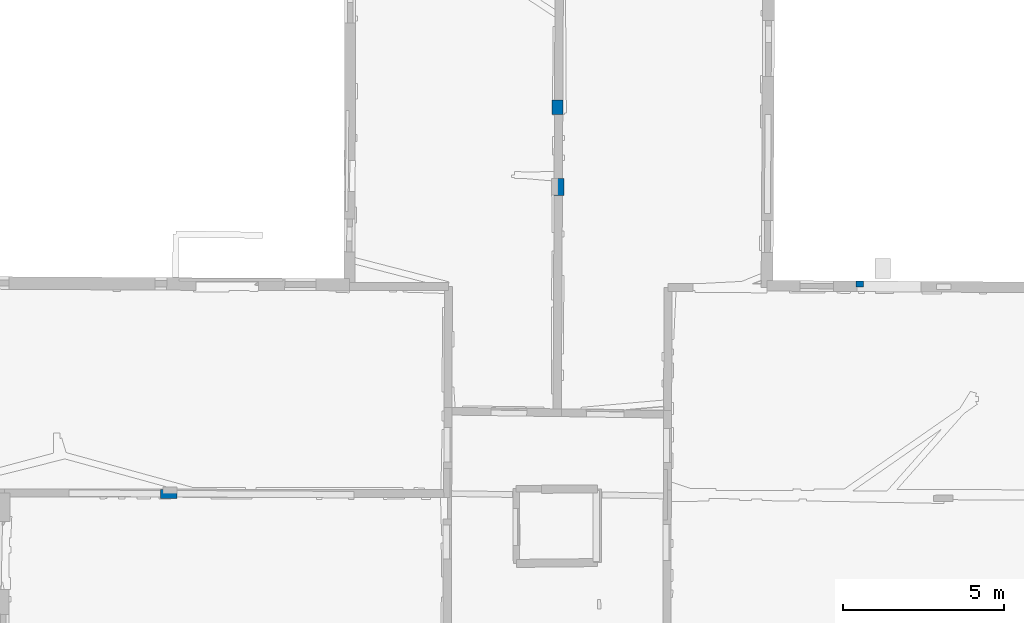
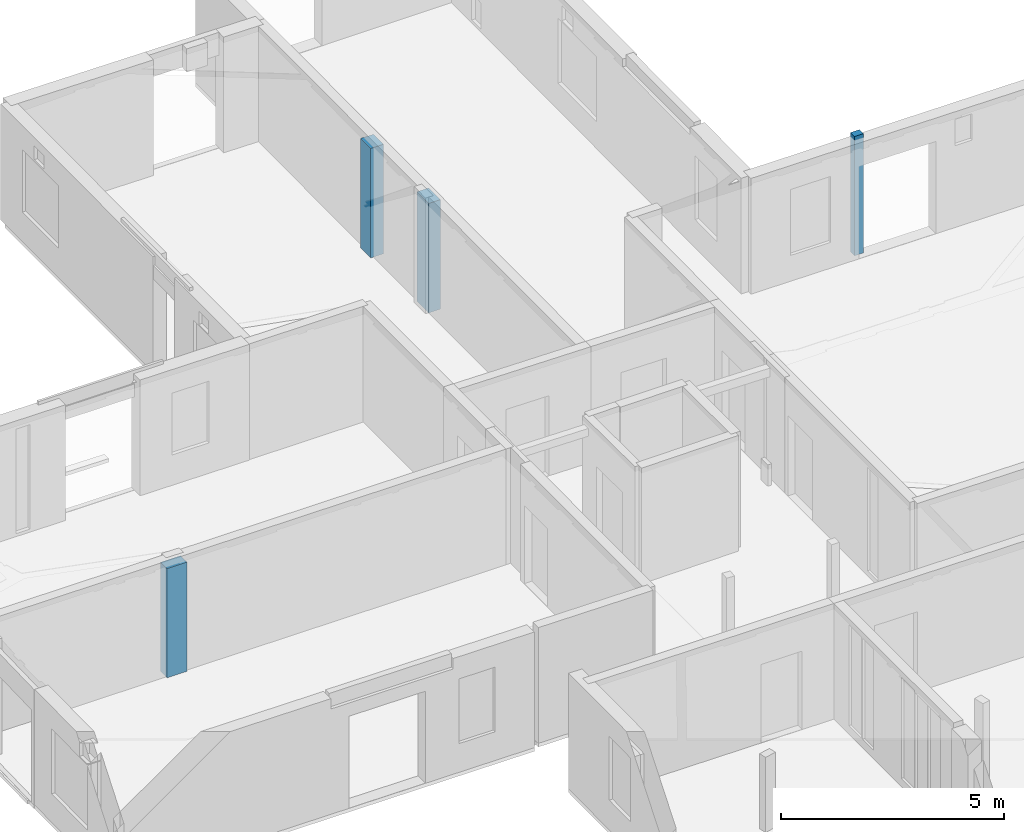
# One storey, part 2 of 17: 4 columns.
"""IFC2X3 building model written with IfcOpenShell, lengths in metres."""

import ifcopenshell
import ifcopenshell.guid

model = None  # the IFC model being written
_history = None  # IfcOwnerHistory: only IFC2X3 demands one
_inside = {}  # id of a spatial element -> (the spatial element, [elements in it])
_under = {}  # id of a project, library or spatial element -> (it, [spatial elements below it])
_declared = {}  # id of a project -> (the project, [libraries it declares])
_typed = {}  # id of a type object -> (the type object, [elements of that type])
_made_of = {}  # id of a material, layer set ... -> (it, [elements and type objects made of it])


def new_model(schema):
    """Start an empty IFC model of exactly this schema.

    Asked for "IFC4X3", IfcOpenShell would pick the latest addendum, in which some entities
    have other attributes; the version numbers below select the first issue.
    IFC2X3 requires an IfcOwnerHistory on every rooted entity: one is made here for all.
    """
    global model, _history
    if schema == "IFC4X3":
        model = ifcopenshell.file(schema_version=(4, 3, 0, 0))
    else:
        model = ifcopenshell.file(schema=schema)
    _inside.clear()
    _under.clear()
    _declared.clear()
    _typed.clear()
    _made_of.clear()
    _history = None
    if model.schema == "IFC2X3":
        org = make("IfcOrganization", Name="unknown")
        user = make(
            "IfcPersonAndOrganization",
            ThePerson=make("IfcPerson", FamilyName="unknown"),
            TheOrganization=org,
        )
        app = make(
            "IfcApplication",
            ApplicationDeveloper=org,
            Version="unknown",
            ApplicationFullName="unknown",
            ApplicationIdentifier="unknown",
        )
        _history = make(
            "IfcOwnerHistory",
            OwningUser=user,
            OwningApplication=app,
            ChangeAction="ADDED",
            CreationDate=0,
        )
    return model


def make(cls, **values):
    """One entity of the class cls with the attributes given. An attribute that is None is left unset."""
    return model.create_entity(
        cls, **{name: value for name, value in values.items() if value is not None}
    )


def entity(cls, *values):
    """Any entity or typed value of the class cls, its attributes in the order of the schema. None: left unset."""
    e = model.create_entity(cls)
    for i, value in enumerate(values):
        if value is not None:
            e[i] = value
    return e


def rooted(cls, **values):
    """An entity with a GlobalId (a new one), such as an element, a storey or a relation."""
    return make(cls, GlobalId=ifcopenshell.guid.new(), OwnerHistory=_history, **values)


def si_unit(unit_type, name, prefix=None):
    """IfcSIUnit, for example si_unit("LENGTHUNIT", "METRE", prefix="MILLI")."""
    return make("IfcSIUnit", UnitType=unit_type, Prefix=prefix, Name=name)


def converted_unit(unit_type, name, factor, base, dimensions=None, offset=None):
    """IfcConversionBasedUnit, such as the inch: factor (a typed value) times the base unit."""
    return make(
        "IfcConversionBasedUnit"
        if offset is None
        else "IfcConversionBasedUnitWithOffset",
        ConversionOffset=offset,
        Dimensions=None
        if dimensions is None
        else entity("IfcDimensionalExponents", *dimensions),
        UnitType=unit_type,
        Name=name,
        ConversionFactor=make(
            "IfcMeasureWithUnit", ValueComponent=factor, UnitComponent=base
        ),
    )


def derived_unit(unit_type, elements):
    """IfcDerivedUnit: a product of units, each with its exponent."""
    return make(
        "IfcDerivedUnit",
        Elements=[
            make("IfcDerivedUnitElement", Unit=unit, Exponent=power)
            for unit, power in elements
        ],
        UnitType=unit_type,
    )


def assignment(units):
    """IfcUnitAssignment: the units of a project."""
    return None if units is None else make("IfcUnitAssignment", Units=units)


def point(xyz):
    """IfcCartesianPoint."""
    return None if xyz is None else make("IfcCartesianPoint", Coordinates=xyz)


def direction(xyz):
    """IfcDirection."""
    return None if xyz is None else make("IfcDirection", DirectionRatios=xyz)


def frame(location, z_axis=None, x_axis=None):
    """IfcAxis2Placement3D, a coordinate frame: its origin and axes. An axis left out is left unset."""
    return make(
        "IfcAxis2Placement3D",
        Location=point(location),
        Axis=direction(z_axis),
        RefDirection=direction(x_axis),
    )


def frame_2d(location, x_axis=None):
    """IfcAxis2Placement2D, a coordinate frame in the plane: its origin and x axis."""
    return make(
        "IfcAxis2Placement2D", Location=point(location), RefDirection=direction(x_axis)
    )


def origin():
    """The frame at (0, 0, 0) with its axes left unset."""
    return frame((0.0, 0.0, 0.0))


def origin_2d_with_axis():
    """The frame at (0, 0) in the plane with the x axis (1, 0) written out."""
    return frame_2d((0.0, 0.0), x_axis=(1.0, 0.0))


def place(relative_to, where):
    """IfcLocalPlacement: puts the frame where relative to a parent placement (None: the world)."""
    return make(
        "IfcLocalPlacement", PlacementRelTo=relative_to, RelativePlacement=where
    )


def context(
    kind, dimensions, precision=None, world=None, true_north=None, identifier=None
):
    """IfcGeometricRepresentationContext, for example the 3D "Model" context."""
    return make(
        "IfcGeometricRepresentationContext",
        ContextIdentifier=identifier,
        ContextType=kind,
        CoordinateSpaceDimension=dimensions,
        Precision=precision,
        WorldCoordinateSystem=world,
        TrueNorth=true_north,
    )


def subcontext(parent, identifier, kind, view, scale=None):
    """IfcGeometricRepresentationSubContext, for example "Body" below "Model"."""
    return make(
        "IfcGeometricRepresentationSubContext",
        ContextIdentifier=identifier,
        ContextType=kind,
        ParentContext=parent,
        TargetScale=scale,
        TargetView=view,
    )


def project(units=None, contexts=None):
    """IfcProject with its units and contexts."""
    return rooted(
        "IfcProject",
        Name="project",
        RepresentationContexts=contexts,
        UnitsInContext=assignment(units),
    )


def spatial(cls, under=None, at=None, **own):
    """A site, building, storey or space (cls), placed at a placement, below another one or the project."""
    s = rooted(cls, ObjectPlacement=at, **own)
    if under is not None:
        _under.setdefault(under.id(), (under, []))[1].append(s)
    return s


def profile(cls, at=None, kind="AREA", **sizes):
    """A parametric profile (cls). Its sizes go by their IFC names, for example OverallWidth=200.0."""
    return make(cls, ProfileType=kind, Position=at, **sizes)


def rectangle(**sizes):
    """IfcRectangleProfileDef."""
    return profile("IfcRectangleProfileDef", **sizes)


def extrude(swept, where, along, depth):
    """IfcExtrudedAreaSolid: the profile swept, set in the frame where, extruded along a direction by depth."""
    return make(
        "IfcExtrudedAreaSolid",
        SweptArea=swept,
        Position=where,
        ExtrudedDirection=direction(along),
        Depth=depth,
    )


def shape(context_of_items, identifier, shape_type, items):
    """IfcShapeRepresentation: the items that make up one representation, for example the "Body"."""
    return make(
        "IfcShapeRepresentation",
        ContextOfItems=context_of_items,
        RepresentationIdentifier=identifier,
        RepresentationType=shape_type,
        Items=items,
    )


def source(mapping_origin, context_of_items, identifier, shape_type, items):
    """IfcRepresentationMap: a shape defined once, which mapped items show again and again."""
    return make(
        "IfcRepresentationMap",
        MappingOrigin=mapping_origin,
        MappedRepresentation=shape(context_of_items, identifier, shape_type, items),
    )


def transform(
    local_origin,
    x_axis=None,
    y_axis=None,
    z_axis=None,
    scale=None,
    scale2=None,
    scale3=None,
    uniform=True,
):
    """IfcCartesianTransformationOperator3D, or its non-uniform kind. x_axis, y_axis, z_axis: its Axis1, 2, 3."""
    if uniform:
        return make(
            "IfcCartesianTransformationOperator3D",
            Axis1=direction(x_axis),
            Axis2=direction(y_axis),
            LocalOrigin=point(local_origin),
            Scale=scale,
            Axis3=direction(z_axis),
        )
    return make(
        "IfcCartesianTransformationOperator3DnonUniform",
        Axis1=direction(x_axis),
        Axis2=direction(y_axis),
        LocalOrigin=point(local_origin),
        Scale=scale,
        Axis3=direction(z_axis),
        Scale2=scale2,
        Scale3=scale3,
    )


def mapped(mapping_source, mapping_target):
    """IfcMappedItem: shows the shape of a source again, moved by a transform."""
    return make(
        "IfcMappedItem", MappingSource=mapping_source, MappingTarget=mapping_target
    )


def material(Name=None, Category=None):
    """IfcMaterial."""
    return make("IfcMaterial", Name=Name, Category=Category)


def made_of(thing, what):
    """Note that an element or type object is made of a material, layer set ...; save() writes the relation."""
    if what is not None:
        _made_of.setdefault(what.id(), (what, []))[1].append(thing)
    return thing


def type_object(cls, material=None, **own):
    """A type object (cls), such as IfcWallType, which elements share."""
    return made_of(rooted(cls, **own), material)


def type_shapes(of_type, sources):
    """Give a type object the sources (RepresentationMaps) that its elements show as mapped items."""
    of_type.RepresentationMaps = sources


def element(
    cls,
    number,
    at=None,
    inside=None,
    cuts=None,
    type_object=None,
    material=None,
    context=None,
    identifier="Body",
    shape_type=None,
    held_by="IfcProductDefinitionShape",
    body=None,
    shapes=None,
    **own,
):
    """One element of the class cls, such as IfcWall. Its Tag is "e" and its number.

    at: its placement. inside: the storey or other place that contains it. cuts: it is an
    opening in that element (IfcRelVoidsElement). A single representation is given by context,
    identifier, shape_type and body (its items); several are given by shapes. held_by: the class
    of the entity that holds the representations. save() writes the other relations.
    """
    e = rooted(cls, Tag="e%d" % number, ObjectPlacement=at, **own)
    if body is not None:
        shapes = [shape(context, identifier, shape_type, body)]
    if shapes is not None:
        e.Representation = make(held_by, Representations=shapes)
    if inside is not None:
        _inside.setdefault(inside.id(), (inside, []))[1].append(e)
    if cuts is not None:
        rooted(
            "IfcRelVoidsElement", RelatingBuildingElement=cuts, RelatedOpeningElement=e
        )
    if type_object is not None:
        _typed.setdefault(type_object.id(), (type_object, []))[1].append(e)
    return made_of(e, material)


def aggregate(whole, parts):
    """IfcRelAggregates: a whole, such as a stair, and the parts it consists of."""
    return rooted("IfcRelAggregates", RelatingObject=whole, RelatedObjects=parts)


def save(model, path):
    """Write the relations noted so far, then the file.

    IfcRelAggregates (storeys below a building ...), IfcRelContainedInSpatialStructure (elements
    in a storey), IfcRelDefinesByType, IfcRelAssociatesMaterial and IfcRelDeclares: one each for
    every whole, place, type object, material and project.
    """
    for whole, parts in _under.values():
        aggregate(whole, parts)
    for where, things in _inside.values():
        rooted(
            "IfcRelContainedInSpatialStructure",
            RelatedElements=things,
            RelatingStructure=where,
        )
    for kind, things in _typed.values():
        rooted("IfcRelDefinesByType", RelatedObjects=things, RelatingType=kind)
    for what, things in _made_of.values():
        rooted("IfcRelAssociatesMaterial", RelatedObjects=things, RelatingMaterial=what)
    for by, libraries in _declared.values():
        rooted("IfcRelDeclares", RelatingContext=by, RelatedDefinitions=libraries)
    model.write(path)


model = new_model("IFC2X3")

# Units and contexts
model_context = context("Model", 3, precision=1e-05, world=origin(), true_north=direction((0.0, 1.0)))
body_context = subcontext(model_context, "Body", "Model", "MODEL_VIEW")
ifc_project = project(units=[si_unit("LENGTHUNIT", "METRE"), si_unit("AREAUNIT", "SQUARE_METRE"), si_unit("VOLUMEUNIT", "CUBIC_METRE"), converted_unit("PLANEANGLEUNIT", "DEGREE", entity("IfcRatioMeasure", 0.0174532925199433), si_unit("PLANEANGLEUNIT", "RADIAN"), dimensions=[0, 0, 0, 0, 0, 0, 0]), si_unit("MASSUNIT", "GRAM", prefix="KILO"), derived_unit("MASSDENSITYUNIT", [(si_unit("MASSUNIT", "GRAM", prefix="KILO"), 1), (si_unit("LENGTHUNIT", "METRE"), -3)]), derived_unit("MOMENTOFINERTIAUNIT", [(si_unit("LENGTHUNIT", "METRE"), 4)]), si_unit("TIMEUNIT", "SECOND"), si_unit("FREQUENCYUNIT", "HERTZ"), si_unit("THERMODYNAMICTEMPERATUREUNIT", "DEGREE_CELSIUS"), derived_unit("THERMALTRANSMITTANCEUNIT", [(si_unit("MASSUNIT", "GRAM", prefix="KILO"), 1), (si_unit("THERMODYNAMICTEMPERATUREUNIT", "KELVIN"), -1), (si_unit("TIMEUNIT", "SECOND"), -3)]), derived_unit("VOLUMETRICFLOWRATEUNIT", [(si_unit("LENGTHUNIT", "METRE"), 3), (si_unit("TIMEUNIT", "SECOND"), -1)]), si_unit("ELECTRICCURRENTUNIT", "AMPERE"), si_unit("ELECTRICVOLTAGEUNIT", "VOLT"), si_unit("POWERUNIT", "WATT"), si_unit("FORCEUNIT", "NEWTON", prefix="KILO"), si_unit("ILLUMINANCEUNIT", "LUX"), si_unit("LUMINOUSFLUXUNIT", "LUMEN"), si_unit("LUMINOUSINTENSITYUNIT", "CANDELA"), derived_unit("USERDEFINED", [(si_unit("MASSUNIT", "GRAM", prefix="KILO"), -1), (si_unit("LENGTHUNIT", "METRE"), -2), (si_unit("TIMEUNIT", "SECOND"), 3), (si_unit("LUMINOUSFLUXUNIT", "LUMEN"), 1)]), derived_unit("LINEARVELOCITYUNIT", [(si_unit("LENGTHUNIT", "METRE"), 1), (si_unit("TIMEUNIT", "SECOND"), -1)]), si_unit("PRESSUREUNIT", "PASCAL"), derived_unit("USERDEFINED", [(si_unit("LENGTHUNIT", "METRE"), -2), (si_unit("MASSUNIT", "GRAM", prefix="KILO"), 1), (si_unit("TIMEUNIT", "SECOND"), -2)]), derived_unit("LINEARFORCEUNIT", [(si_unit("MASSUNIT", "GRAM", prefix="KILO"), 1), (si_unit("LENGTHUNIT", "METRE"), 1), (si_unit("TIMEUNIT", "SECOND"), -2), (si_unit("LENGTHUNIT", "METRE"), -1)]), derived_unit("PLANARFORCEUNIT", [(si_unit("MASSUNIT", "GRAM", prefix="KILO"), 1), (si_unit("LENGTHUNIT", "METRE"), 1), (si_unit("TIMEUNIT", "SECOND"), -2), (si_unit("LENGTHUNIT", "METRE"), -2)])], contexts=[model_context])

# Site, building, storey
placement = place(None, origin())
site = spatial("IfcSite", under=ifc_project, at=placement, CompositionType="ELEMENT")
building = spatial("IfcBuilding", under=site, at=placement, CompositionType="ELEMENT")
storey_placement = place(placement, frame((0.0, 0.0, 5.56662893295288)))
storey = spatial("IfcBuildingStorey", under=building, at=storey_placement, Name="Level 3", CompositionType="ELEMENT", Elevation=5.56662893295288)

# Columns
ifc_material = material()
column_type_1 = type_object("IfcColumnType", Name="Rectangular Column:230 x 180mm", PredefinedType="COLUMN", material=ifc_material)
shared_shape_1 = source(origin(), body_context, "Body", "SweptSolid", [
    extrude(rectangle(XDim=0.230005458767203, YDim=0.180000007152557, at=origin_2d_with_axis()), frame((0.0, 0.0, 0.0), z_axis=(0.0, 0.0, 1.0), x_axis=(0.0, -1.0, 0.0)), (0.0, 0.0, 1.0), 3.2649998664856),
])
type_shapes(column_type_1, [shared_shape_1])
column_1_placement = place(placement, frame((15.753036944752, 64.1567285511638, 5.56699991226196), z_axis=(0.0, 0.0, 1.0), x_axis=(0.00589723160695898, 0.999982611178501, 0.0)))
element("IfcColumn", 1, at=column_1_placement, inside=storey, type_object=column_type_1, Name="Rectangular Column:230 x 180mm", ObjectType="Rectangular Column:230 x 180mm", context=body_context, shape_type="MappedRepresentation", body=[
    mapped(shared_shape_1, transform((0.0, 0.0, 0.0), scale=1.0)),
])
column_type_2 = type_object("IfcColumnType", Name="Rectangular Column:452 x 330mm", PredefinedType="COLUMN", material=ifc_material)
shared_shape_2 = source(origin(), body_context, "Body", "SweptSolid", [
    extrude(rectangle(XDim=0.452397624066148, YDim=0.330000013113022, at=origin_2d_with_axis()), frame((0.0, 0.0, 0.0), z_axis=(0.0, 0.0, 1.0), x_axis=(0.0, -1.0, 0.0)), (0.0, 0.0, 1.0), 2.99500036239624),
])
type_shapes(column_type_2, [shared_shape_2])
column_2_placement = place(placement, frame((6.37197268783706, 69.6456386667009, 5.56699991226196), z_axis=(0.0, 0.0, 1.0), x_axis=(0.999988844921457, -0.00472334972769604, 0.0)))
element("IfcColumn", 2, at=column_2_placement, inside=storey, type_object=column_type_2, Name="Rectangular Column:452 x 330mm", ObjectType="Rectangular Column:452 x 330mm", context=body_context, shape_type="MappedRepresentation", body=[
    mapped(shared_shape_2, transform((0.0, 0.0, 0.0), scale=1.0)),
])
column_type_3 = type_object("IfcColumnType", Name="Rectangular Column:527 x 310mm", PredefinedType="COLUMN", material=ifc_material)
shared_shape_3 = source(origin(), body_context, "Body", "SweptSolid", [
    extrude(rectangle(XDim=0.52729212759161, YDim=0.310000002384186, at=origin_2d_with_axis()), frame((0.0, 0.0, 0.0), z_axis=(0.0, 0.0, 1.0), x_axis=(0.0, -1.0, 0.0)), (0.0, 0.0, 1.0), 2.99500036239624),
])
type_shapes(column_type_3, [shared_shape_3])
column_3_placement = place(placement, frame((6.41198228042446, 67.1714146982103, 5.56699991226196), z_axis=(0.0, 0.0, 1.0), x_axis=(-0.999996618629941, 0.00260052469419976, 0.0)))
element("IfcColumn", 3, at=column_3_placement, inside=storey, type_object=column_type_3, Name="Rectangular Column:527 x 310mm", ObjectType="Rectangular Column:527 x 310mm", context=body_context, shape_type="MappedRepresentation", body=[
    mapped(shared_shape_3, transform((0.0, 0.0, 0.0), scale=1.0)),
])
column_type_4 = type_object("IfcColumnType", Name="Rectangular Column:517 x 290mm", PredefinedType="COLUMN", material=ifc_material)
shared_shape_4 = source(origin(), body_context, "Body", "SweptSolid", [
    extrude(rectangle(XDim=0.517028733685329, YDim=0.28999999165535, at=origin_2d_with_axis()), frame((0.0, 0.0, 0.0), z_axis=(0.0, 0.0, 1.0), x_axis=(0.0, -1.0, 0.0)), (0.0, 0.0, 1.0), 2.98899936676025),
])
type_shapes(column_type_4, [shared_shape_4])
column_4_placement = place(placement, frame((-5.69096908693125, 57.6338296923928, 5.56900024414062), z_axis=(0.0, 0.0, 1.0), x_axis=(0.00125195275340349, 0.999999216306845, 0.0)))
element("IfcColumn", 4, at=column_4_placement, inside=storey, type_object=column_type_4, Name="Rectangular Column:517 x 290mm", ObjectType="Rectangular Column:517 x 290mm", context=body_context, shape_type="MappedRepresentation", body=[
    mapped(shared_shape_4, transform((0.0, 0.0, 0.0), scale=1.0)),
])

save(model, "model.ifc")
